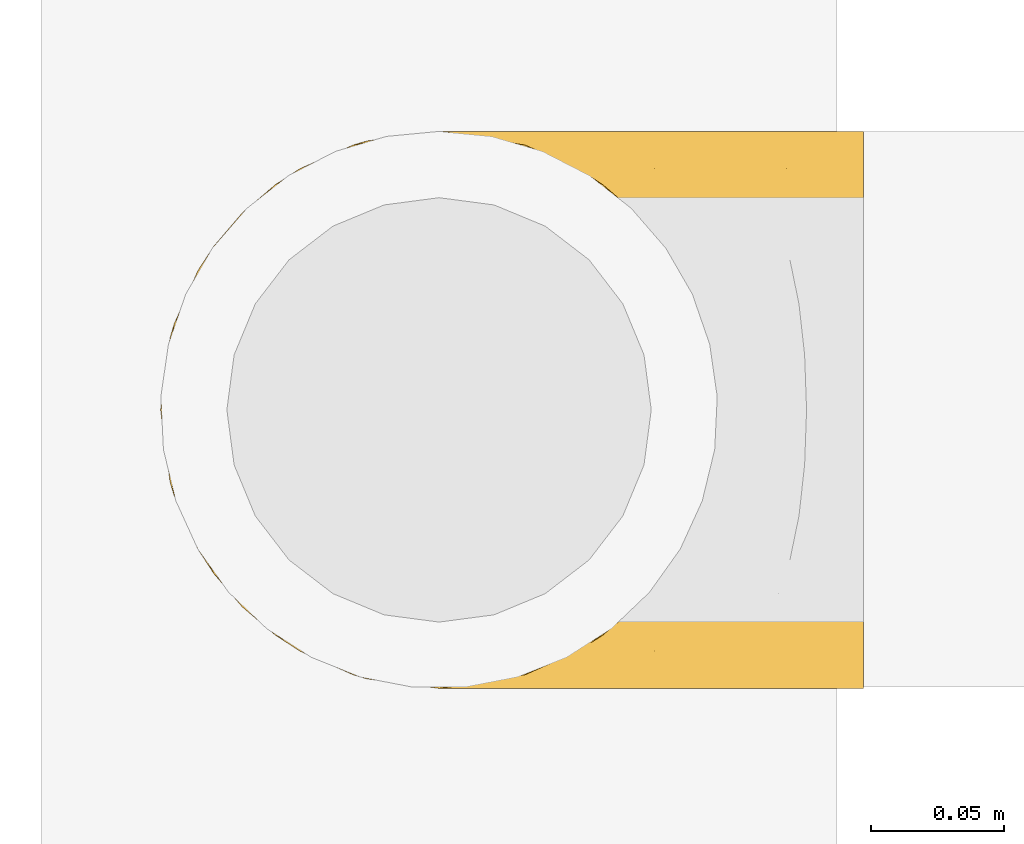
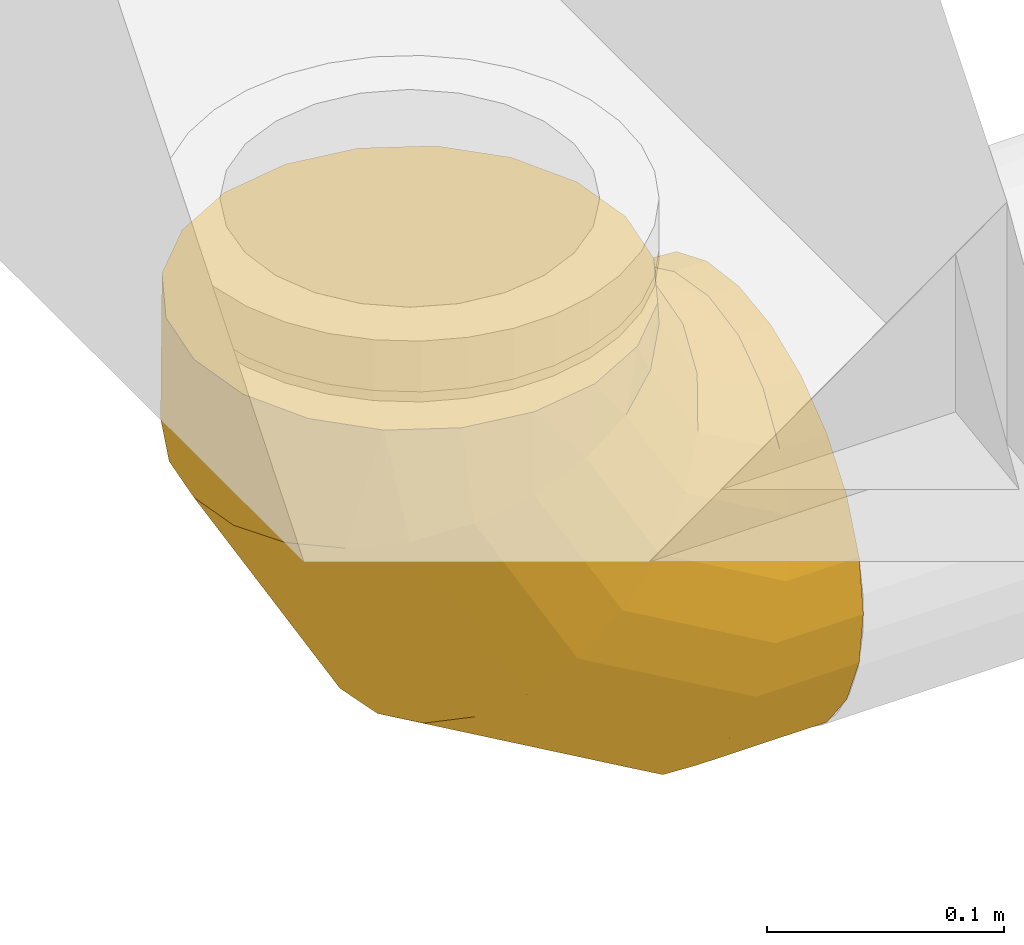
# One storey, part 12 of 62: 1 covering.
"""IFC2X3 building model written with IfcOpenShell, lengths in millimetres."""

from ifc_helpers import new_model, entity, si_unit, converted_unit, derived_unit, direction, frame, origin, place, context, subcontext, project, spatial, faceted_brep, element, save


model = new_model("IFC2X3")

# Units and contexts
model_context = context("Model", 3, precision=0.01, world=origin(), true_north=direction((6.12303176911189e-17, 1.0)))
body_context = subcontext(model_context, "Body", "Model", "MODEL_VIEW")
ifc_project = project(units=[si_unit("LENGTHUNIT", "METRE", prefix="MILLI"), si_unit("AREAUNIT", "SQUARE_METRE"), si_unit("VOLUMEUNIT", "CUBIC_METRE"), converted_unit("PLANEANGLEUNIT", "DEGREE", entity("IfcRatioMeasure", 0.0174532925199433), si_unit("PLANEANGLEUNIT", "RADIAN"), dimensions=[0, 0, 0, 0, 0, 0, 0]), si_unit("MASSUNIT", "GRAM", prefix="KILO"), derived_unit("MASSDENSITYUNIT", [(si_unit("MASSUNIT", "GRAM", prefix="KILO"), 1), (si_unit("LENGTHUNIT", "METRE"), -3)]), derived_unit("MOMENTOFINERTIAUNIT", [(si_unit("LENGTHUNIT", "METRE"), 4)]), si_unit("TIMEUNIT", "SECOND"), si_unit("FREQUENCYUNIT", "HERTZ"), si_unit("THERMODYNAMICTEMPERATUREUNIT", "DEGREE_CELSIUS"), derived_unit("THERMALTRANSMITTANCEUNIT", [(si_unit("MASSUNIT", "GRAM", prefix="KILO"), 1), (si_unit("THERMODYNAMICTEMPERATUREUNIT", "KELVIN"), -1), (si_unit("TIMEUNIT", "SECOND"), -3)]), derived_unit("VOLUMETRICFLOWRATEUNIT", [(si_unit("LENGTHUNIT", "METRE"), 3), (si_unit("TIMEUNIT", "SECOND"), -1)]), derived_unit("MASSFLOWRATEUNIT", [(si_unit("MASSUNIT", "GRAM", prefix="KILO"), 1), (si_unit("TIMEUNIT", "SECOND"), -1)]), derived_unit("ROTATIONALFREQUENCYUNIT", [(si_unit("TIMEUNIT", "SECOND"), -1)]), si_unit("ELECTRICCURRENTUNIT", "AMPERE"), si_unit("ELECTRICVOLTAGEUNIT", "VOLT"), si_unit("POWERUNIT", "WATT"), si_unit("FORCEUNIT", "NEWTON", prefix="KILO"), si_unit("ILLUMINANCEUNIT", "LUX"), si_unit("LUMINOUSFLUXUNIT", "LUMEN"), si_unit("LUMINOUSINTENSITYUNIT", "CANDELA"), derived_unit("USERDEFINED", [(si_unit("MASSUNIT", "GRAM", prefix="KILO"), -1), (si_unit("LENGTHUNIT", "METRE"), -2), (si_unit("TIMEUNIT", "SECOND"), 3), (si_unit("LUMINOUSFLUXUNIT", "LUMEN"), 1)]), derived_unit("LINEARVELOCITYUNIT", [(si_unit("LENGTHUNIT", "METRE"), 1), (si_unit("TIMEUNIT", "SECOND"), -1)]), si_unit("PRESSUREUNIT", "PASCAL"), derived_unit("USERDEFINED", [(si_unit("LENGTHUNIT", "METRE"), -2), (si_unit("MASSUNIT", "GRAM", prefix="KILO"), 1), (si_unit("TIMEUNIT", "SECOND"), -2)]), derived_unit("LINEARFORCEUNIT", [(si_unit("MASSUNIT", "GRAM", prefix="KILO"), 1), (si_unit("LENGTHUNIT", "METRE"), 1), (si_unit("TIMEUNIT", "SECOND"), -2), (si_unit("LENGTHUNIT", "METRE"), -1)]), derived_unit("PLANARFORCEUNIT", [(si_unit("MASSUNIT", "GRAM", prefix="KILO"), 1), (si_unit("LENGTHUNIT", "METRE"), 1), (si_unit("TIMEUNIT", "SECOND"), -2), (si_unit("LENGTHUNIT", "METRE"), -2)])], contexts=[model_context])

# Site, building, storey
site_placement = place(None, origin())
site = spatial("IfcSite", under=ifc_project, at=site_placement, CompositionType="ELEMENT")
building_placement = place(site_placement, origin())
building = spatial("IfcBuilding", under=site, at=building_placement, CompositionType="ELEMENT")
storey_placement = place(building_placement, frame((0.0, 0.0, 24000.0)))
storey = spatial("IfcBuildingStorey", under=building, at=storey_placement, CompositionType="ELEMENT", Elevation=24000.0)

# Covering
covering_placement = place(storey_placement, frame((67610.13, 5604.78, 3193.4)))
element("IfcCovering", 1, at=covering_placement, inside=storey, PredefinedType="INSULATION", context=body_context, shape_type="Brep", body=[
    faceted_brep([(106.6, 211.6, 266.6), (74.15, 206.46, 266.6), (44.88, 191.54, 266.6), (21.65, 168.31, 266.6), (6.73, 139.04, 266.6), (1.6, 106.6, 266.6), (6.73, 74.15, 266.6), (21.65, 44.88, 266.6), (44.88, 21.65, 266.6), (74.15, 6.73, 266.6), (106.6, 1.6, 266.6), (139.04, 6.73, 266.6), (168.31, 21.65, 266.6), (191.54, 44.88, 266.6), (206.46, 74.15, 266.6), (211.6, 106.6, 266.6), (206.46, 139.04, 266.6), (191.54, 168.31, 266.6), (168.31, 191.54, 266.6), (139.04, 206.46, 266.6), (266.6, 54.1, 15.66), (266.6, 79.42, 5.17), (266.6, 106.6, 1.6), (266.6, 133.77, 5.17), (266.6, 159.1, 15.66), (266.6, 180.84, 32.35), (266.6, 197.53, 54.1), (266.6, 208.02, 79.42), (266.6, 211.6, 106.6), (266.6, 208.02, 133.77), (266.6, 197.53, 159.1), (266.6, 180.84, 180.84), (266.6, 159.1, 197.53), (266.6, 133.77, 208.02), (266.6, 106.6, 211.6), (266.6, 79.42, 208.02), (266.6, 54.1, 197.53), (266.6, 32.35, 180.84), (266.6, 15.66, 159.1), (266.6, 5.17, 133.77), (266.6, 1.6, 106.6), (266.6, 5.17, 79.42), (266.6, 15.66, 54.1), (266.6, 32.35, 32.35), (195.59, 106.6, 1.6), (196.55, 133.77, 5.17), (199.36, 159.1, 15.66), (203.83, 180.84, 32.35), (209.66, 197.53, 54.1), (216.44, 208.02, 79.42), (223.72, 211.6, 106.6), (231.01, 208.02, 133.77), (237.79, 197.53, 159.1), (243.62, 180.84, 180.84), (248.09, 159.1, 197.53), (250.9, 133.77, 208.02), (251.86, 106.6, 211.6), (250.9, 79.42, 208.02), (248.09, 54.1, 197.53), (243.62, 32.35, 180.84), (231.01, 5.17, 133.77), (223.72, 1.6, 106.6), (237.79, 15.66, 159.1), (216.44, 5.17, 79.42), (209.66, 15.66, 54.1), (203.83, 32.35, 32.35), (199.36, 54.1, 15.66), (196.55, 79.42, 5.17), (72.6, 106.6, 72.6), (75.22, 133.77, 75.22), (82.9, 159.1, 82.9), (95.12, 180.84, 95.12), (111.03, 197.53, 111.03), (129.57, 208.02, 129.57), (149.47, 211.6, 149.47), (169.36, 208.02, 169.36), (187.9, 197.53, 187.9), (203.82, 180.84, 203.82), (216.03, 159.1, 216.03), (223.71, 133.77, 223.71), (226.33, 106.6, 226.33), (223.71, 79.42, 223.71), (216.03, 54.1, 216.03), (203.82, 32.35, 203.82), (169.36, 5.17, 169.36), (149.47, 1.6, 149.47), (187.9, 15.66, 187.9), (129.57, 5.17, 129.57), (111.03, 15.66, 111.03), (95.12, 32.35, 95.12), (82.9, 54.1, 82.9), (75.22, 79.42, 75.22), (1.6, 106.6, 195.59), (5.17, 133.77, 196.55), (15.66, 159.1, 199.36), (32.35, 180.84, 203.83), (54.1, 197.53, 209.66), (79.42, 208.02, 216.44), (106.6, 211.6, 223.72), (133.77, 208.02, 231.01), (159.1, 197.53, 237.79), (180.84, 180.84, 243.62), (197.53, 159.1, 248.09), (208.02, 133.77, 250.9), (211.6, 106.6, 251.86), (208.02, 79.42, 250.9), (197.53, 54.1, 248.09), (180.84, 32.35, 243.62), (133.77, 5.17, 231.01), (106.6, 1.6, 223.72), (159.1, 15.66, 237.79), (79.42, 5.17, 216.44), (54.1, 15.66, 209.66), (32.35, 32.35, 203.83), (15.66, 54.1, 199.36), (5.17, 79.42, 196.55)], [[[0, 1, 2, 3, 4, 5, 6, 7, 8, 9, 10, 11, 12, 13, 14, 15, 16, 17, 18, 19]], [[20, 21, 22, 23, 24, 25, 26, 27, 28, 29, 30, 31, 32, 33, 34, 35, 36, 37, 38, 39, 40, 41, 42, 43]], [[22, 44, 45, 23]], [[23, 45, 46, 24]], [[24, 46, 47, 25]], [[25, 47, 48, 26]], [[26, 48, 49, 27]], [[50, 28, 27, 49]], [[51, 52, 30, 29]], [[50, 51, 29, 28]], [[53, 31, 30, 52]], [[54, 55, 33, 32]], [[54, 32, 31, 53]], [[56, 34, 33, 55]], [[57, 58, 36, 35]], [[56, 57, 35, 34]], [[37, 36, 58, 59]], [[60, 61, 40, 39]], [[62, 60, 39, 38]], [[59, 62, 38, 37]], [[41, 40, 61, 63]], [[42, 41, 63, 64]], [[64, 65, 43, 42]], [[21, 20, 66, 67]], [[22, 21, 67, 44]], [[65, 66, 20, 43]], [[45, 44, 68, 69]], [[46, 45, 69, 70]], [[70, 71, 47, 46]], [[48, 47, 71, 72]], [[49, 48, 72, 73]], [[50, 49, 73, 74]], [[75, 76, 52, 51]], [[74, 75, 51, 50]], [[53, 52, 76, 77]], [[78, 79, 55, 54]], [[77, 78, 54, 53]], [[56, 55, 79, 80]], [[81, 82, 58, 57]], [[80, 81, 57, 56]], [[59, 58, 82, 83]], [[84, 85, 61, 60]], [[86, 84, 60, 62]], [[83, 86, 62, 59]], [[63, 61, 85, 87]], [[64, 63, 87, 88]], [[65, 64, 88, 89]], [[67, 66, 90, 91]], [[44, 67, 91, 68]], [[89, 90, 66, 65]], [[69, 68, 92, 93]], [[70, 69, 93, 94]], [[94, 95, 71, 70]], [[72, 71, 95, 96]], [[73, 72, 96, 97]], [[74, 73, 97, 98]], [[99, 100, 76, 75]], [[98, 99, 75, 74]], [[77, 76, 100, 101]], [[102, 103, 79, 78]], [[101, 102, 78, 77]], [[80, 79, 103, 104]], [[105, 106, 82, 81]], [[104, 105, 81, 80]], [[83, 82, 106, 107]], [[108, 109, 85, 84]], [[110, 108, 84, 86]], [[107, 110, 86, 83]], [[87, 85, 109, 111]], [[88, 87, 111, 112]], [[89, 88, 112, 113]], [[91, 90, 114, 115]], [[68, 91, 115, 92]], [[113, 114, 90, 89]], [[93, 5, 4]], [[94, 4, 3]], [[5, 93, 92]], [[93, 4, 94]], [[3, 95, 94]], [[96, 2, 1]], [[97, 1, 0]], [[95, 2, 96]], [[96, 1, 97]], [[0, 98, 97]], [[2, 95, 3]], [[99, 0, 19]], [[100, 19, 18]], [[99, 98, 0]], [[100, 99, 19]], [[18, 101, 100]], [[102, 17, 16]], [[103, 16, 15]], [[102, 101, 17]], [[104, 103, 15]], [[102, 16, 103]], [[17, 101, 18]], [[105, 15, 14]], [[106, 14, 13]], [[105, 104, 15]], [[106, 105, 14]], [[13, 107, 106]], [[110, 12, 11]], [[108, 11, 10]], [[110, 107, 12]], [[109, 108, 10]], [[110, 11, 108]], [[12, 107, 13]], [[9, 8, 112]], [[10, 9, 111]], [[10, 111, 109]], [[111, 9, 112]], [[8, 113, 112]], [[114, 7, 6]], [[115, 6, 5]], [[113, 7, 114]], [[115, 114, 6]], [[92, 115, 5]], [[7, 113, 8]]]),
])

save(model, "model.ifc")
